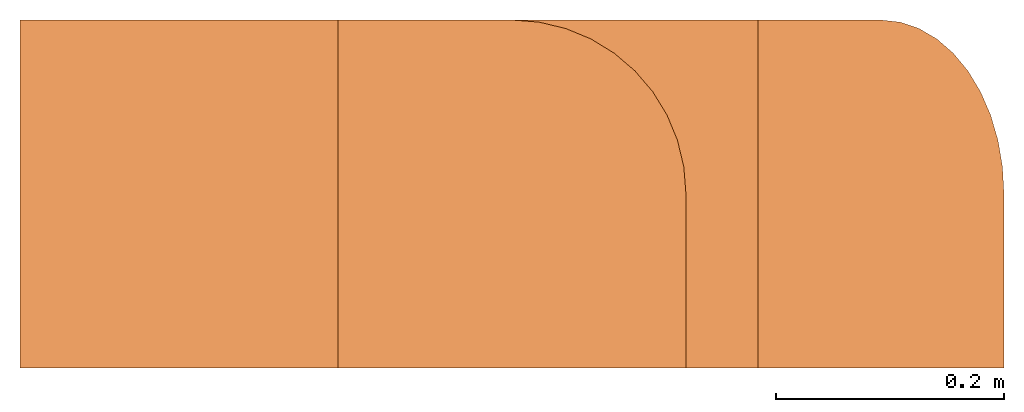
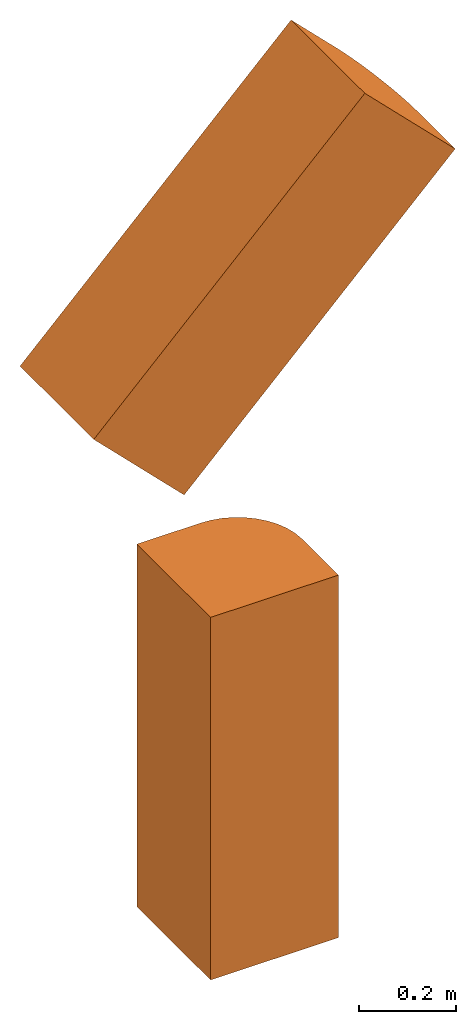
# One storey: 2 proxies.
"""IFC4 building model written with IfcOpenShell, lengths in feet."""

from ifc_helpers import new_model, entity, si_unit, converted_unit, derived_unit, direction, frame, frame_2d, origin, place, context, subcontext, project, spatial, polyline, circle_curve, parameter, trimmed, segment, composite_curve, outline, extrude, source, transform, mapped, type_object, type_shapes, element, save


model = new_model("IFC4")

# Units and contexts
model_context = context("Model", 3, precision=0.0001, world=origin(), true_north=direction((6.12303176911189e-17, 1.0)))
body_context = subcontext(model_context, "Body", "Model", "MODEL_VIEW")
ifc_project = project(units=[converted_unit("LENGTHUNIT", "FOOT", entity("IfcRatioMeasure", 0.3048), si_unit("LENGTHUNIT", "METRE"), dimensions=[1, 0, 0, 0, 0, 0, 0]), converted_unit("AREAUNIT", "SQUARE FOOT", entity("IfcRatioMeasure", 0.09290304), si_unit("AREAUNIT", "SQUARE_METRE"), dimensions=[2, 0, 0, 0, 0, 0, 0]), converted_unit("VOLUMEUNIT", "CUBIC FOOT", entity("IfcRatioMeasure", 0.028316846592), si_unit("VOLUMEUNIT", "CUBIC_METRE"), dimensions=[3, 0, 0, 0, 0, 0, 0]), converted_unit("PLANEANGLEUNIT", "DEGREE", entity("IfcRatioMeasure", 0.0174532925199433), si_unit("PLANEANGLEUNIT", "RADIAN"), dimensions=[0, 0, 0, 0, 0, 0, 0]), si_unit("MASSUNIT", "GRAM", prefix="KILO"), derived_unit("MASSDENSITYUNIT", [(si_unit("MASSUNIT", "GRAM", prefix="KILO"), 1), (si_unit("LENGTHUNIT", "METRE"), -3)]), si_unit("TIMEUNIT", "SECOND"), si_unit("FREQUENCYUNIT", "HERTZ"), si_unit("THERMODYNAMICTEMPERATUREUNIT", "DEGREE_CELSIUS"), derived_unit("THERMALTRANSMITTANCEUNIT", [(si_unit("MASSUNIT", "GRAM", prefix="KILO"), 1), (si_unit("THERMODYNAMICTEMPERATUREUNIT", "KELVIN"), -1), (si_unit("TIMEUNIT", "SECOND"), -3)]), derived_unit("VOLUMETRICFLOWRATEUNIT", [(si_unit("LENGTHUNIT", "METRE"), 3), (si_unit("TIMEUNIT", "SECOND"), -1)]), si_unit("ELECTRICCURRENTUNIT", "AMPERE"), si_unit("ELECTRICVOLTAGEUNIT", "VOLT"), si_unit("POWERUNIT", "WATT"), si_unit("FORCEUNIT", "NEWTON"), si_unit("ILLUMINANCEUNIT", "LUX"), si_unit("LUMINOUSFLUXUNIT", "LUMEN"), si_unit("LUMINOUSINTENSITYUNIT", "CANDELA"), derived_unit("USERDEFINED", [(si_unit("MASSUNIT", "GRAM", prefix="KILO"), -1), (si_unit("LENGTHUNIT", "METRE"), -2), (si_unit("TIMEUNIT", "SECOND"), 3), (si_unit("LUMINOUSFLUXUNIT", "LUMEN"), 1)]), derived_unit("LINEARVELOCITYUNIT", [(si_unit("LENGTHUNIT", "METRE"), 1), (si_unit("TIMEUNIT", "SECOND"), -1)]), si_unit("PRESSUREUNIT", "PASCAL"), derived_unit("USERDEFINED", [(si_unit("LENGTHUNIT", "METRE"), -2), (si_unit("MASSUNIT", "GRAM", prefix="KILO"), 1), (si_unit("TIMEUNIT", "SECOND"), -2)]), derived_unit("LINEARFORCEUNIT", [(si_unit("MASSUNIT", "GRAM", prefix="KILO"), 1), (si_unit("LENGTHUNIT", "METRE"), 1), (si_unit("TIMEUNIT", "SECOND"), -2), (si_unit("LENGTHUNIT", "METRE"), -1)]), derived_unit("PLANARFORCEUNIT", [(si_unit("MASSUNIT", "GRAM", prefix="KILO"), 1), (si_unit("LENGTHUNIT", "METRE"), 1), (si_unit("TIMEUNIT", "SECOND"), -2), (si_unit("LENGTHUNIT", "METRE"), -2)])], contexts=[model_context])

# Site, building, storey
site_placement = place(None, origin())
site = spatial("IfcSite", under=ifc_project, at=site_placement, CompositionType="ELEMENT")
building_placement = place(site_placement, origin())
building = spatial("IfcBuilding", under=site, at=building_placement, CompositionType="ELEMENT")
storey_placement = place(building_placement, origin())
storey = spatial("IfcBuildingStorey", under=building, at=storey_placement, Name="Level 1", CompositionType="ELEMENT", Elevation=0.0)

# Proxies
building_element_proxy_type_1 = type_object("IfcBuildingElementProxyType", Name="Generic Models 2:Generic Models 1", PredefinedType="NOTDEFINED")
shared_shape_1 = source(origin(), body_context, "Body", "SweptSolid", [
    extrude(outline(composite_curve([segment(polyline([(-0.500000000000001, -0.5), (0.499999999999999, -0.5)]), True, "CONTINUOUS"), segment(polyline([(0.499999999999999, -0.5), (0.5, 0.499999999999998)]), True, "CONTINUOUS"), segment(polyline([(0.5, 0.499999999999998), (0.0, 0.5)]), True, "CONTINUOUS"), segment(trimmed(circle_curve(frame_2d((0.0, 0.0), x_axis=(0.0, 1.0)), 0.5), [parameter(360.0)], [parameter(90.0)], True, "PARAMETER"), True, "CONTINUOUS"), segment(polyline([(-0.500000000000002, 0.0), (-0.500000000000001, -0.5)]), True, "CONTINUOUS")], self_intersect=False)), frame((0.0, 0.0, 0.0), z_axis=(0.0, 0.0, 1.0), x_axis=(0.0, -1.0, 0.0)), (0.0, 0.0, 1.0), 3.0),
])
type_shapes(building_element_proxy_type_1, [shared_shape_1])
proxy_1_placement = place(storey_placement, origin())
element("IfcBuildingElementProxy", 1, at=proxy_1_placement, inside=storey, type_object=building_element_proxy_type_1, Name="Generic Models 2:Generic Models 1", ObjectType="Generic Models 2:Generic Models 1", PredefinedType="NOTDEFINED", context=body_context, shape_type="MappedRepresentation", body=[
    mapped(shared_shape_1, transform((0.0, 0.0, 0.0), scale=1.0)),
])
building_element_proxy_type_2 = type_object("IfcBuildingElementProxyType", Name="Generic Models 1:Generic Models 1", PredefinedType="NOTDEFINED")
shared_shape_2 = source(origin(), body_context, "Body", "SweptSolid", [
    extrude(outline(composite_curve([segment(polyline([(-0.500000000000002, -0.5), (0.499999999999998, -0.5)]), True, "CONTINUOUS"), segment(polyline([(0.499999999999998, -0.5), (0.5, 0.499999999999998)]), True, "CONTINUOUS"), segment(polyline([(0.5, 0.499999999999998), (0.0, 0.500000000000001)]), True, "CONTINUOUS"), segment(trimmed(circle_curve(frame_2d((0.0, 0.0), x_axis=(0.0, 1.0)), 0.5), [parameter(360.0)], [parameter(90.0)], True, "PARAMETER"), True, "CONTINUOUS"), segment(polyline([(-0.500000000000001, 0.0), (-0.500000000000002, -0.5)]), True, "CONTINUOUS")], self_intersect=False)), frame((0.353553390593275, 0.500000000000007, 0.358787223388274), z_axis=(0.707106781186547, 0.0, 0.707106781186548), x_axis=(0.0, -1.0, 0.0)), (0.0, 0.0, 1.0), 3.0),
])
type_shapes(building_element_proxy_type_2, [shared_shape_2])
proxy_2_placement = place(storey_placement, frame((-1.41421356237309, -0.500000000000001, 4.08055260483191)))
element("IfcBuildingElementProxy", 2, at=proxy_2_placement, inside=storey, type_object=building_element_proxy_type_2, Name="Generic Models 1:Generic Models 1", ObjectType="Generic Models 1:Generic Models 1", PredefinedType="NOTDEFINED", context=body_context, shape_type="MappedRepresentation", body=[
    mapped(shared_shape_2, transform((0.0, 0.0, 0.0), scale=1.0)),
])

save(model, "model.ifc")
